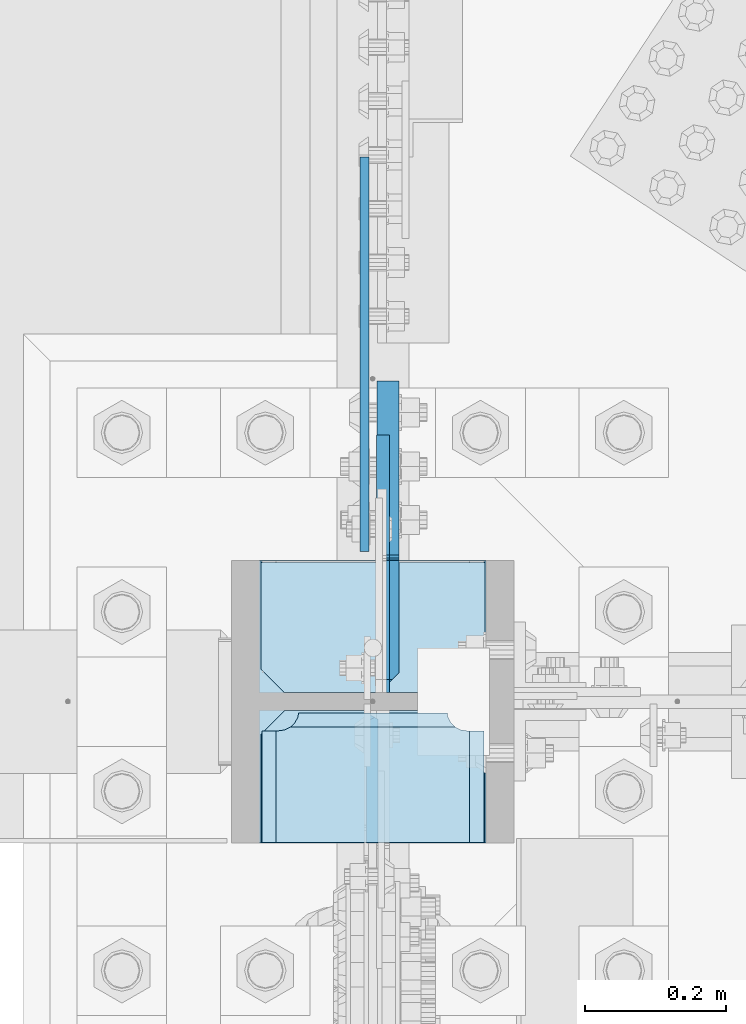
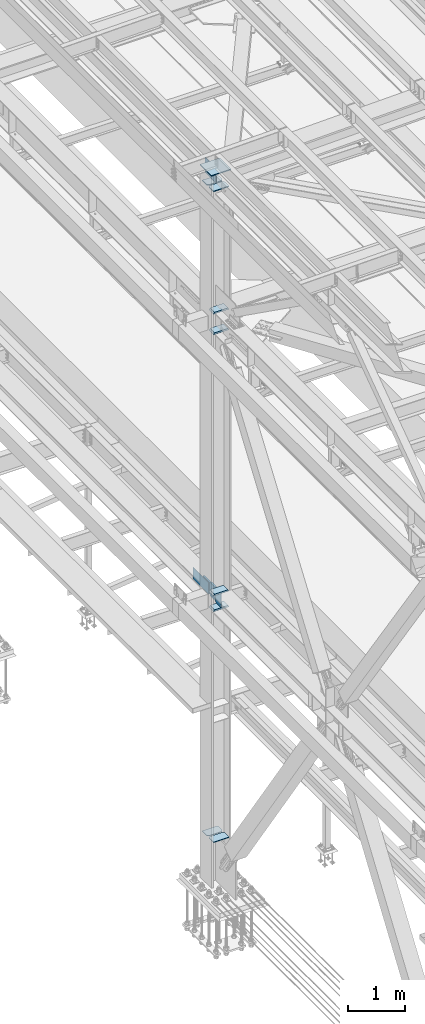
# One storey, part 3274 of 3843: 13 plates, 2 elements without a shape of their own.
"""IFC2X3 building model written with IfcOpenShell, lengths in millimetres."""

import ifcopenshell
import ifcopenshell.guid

model = None  # the IFC model being written
_history = None  # IfcOwnerHistory: only IFC2X3 demands one
_inside = {}  # id of a spatial element -> (the spatial element, [elements in it])
_under = {}  # id of a project, library or spatial element -> (it, [spatial elements below it])
_declared = {}  # id of a project -> (the project, [libraries it declares])
_typed = {}  # id of a type object -> (the type object, [elements of that type])
_made_of = {}  # id of a material, layer set ... -> (it, [elements and type objects made of it])


def new_model(schema):
    """Start an empty IFC model of exactly this schema.

    Asked for "IFC4X3", IfcOpenShell would pick the latest addendum, in which some entities
    have other attributes; the version numbers below select the first issue.
    IFC2X3 requires an IfcOwnerHistory on every rooted entity: one is made here for all.
    """
    global model, _history
    if schema == "IFC4X3":
        model = ifcopenshell.file(schema_version=(4, 3, 0, 0))
    else:
        model = ifcopenshell.file(schema=schema)
    _inside.clear()
    _under.clear()
    _declared.clear()
    _typed.clear()
    _made_of.clear()
    _history = None
    if model.schema == "IFC2X3":
        org = make("IfcOrganization", Name="unknown")
        user = make(
            "IfcPersonAndOrganization",
            ThePerson=make("IfcPerson", FamilyName="unknown"),
            TheOrganization=org,
        )
        app = make(
            "IfcApplication",
            ApplicationDeveloper=org,
            Version="unknown",
            ApplicationFullName="unknown",
            ApplicationIdentifier="unknown",
        )
        _history = make(
            "IfcOwnerHistory",
            OwningUser=user,
            OwningApplication=app,
            ChangeAction="ADDED",
            CreationDate=0,
        )
    return model


def make(cls, **values):
    """One entity of the class cls with the attributes given. An attribute that is None is left unset."""
    return model.create_entity(
        cls, **{name: value for name, value in values.items() if value is not None}
    )


def rooted(cls, **values):
    """An entity with a GlobalId (a new one), such as an element, a storey or a relation."""
    return make(cls, GlobalId=ifcopenshell.guid.new(), OwnerHistory=_history, **values)


def si_unit(unit_type, name, prefix=None):
    """IfcSIUnit, for example si_unit("LENGTHUNIT", "METRE", prefix="MILLI")."""
    return make("IfcSIUnit", UnitType=unit_type, Prefix=prefix, Name=name)


def assignment(units):
    """IfcUnitAssignment: the units of a project."""
    return None if units is None else make("IfcUnitAssignment", Units=units)


def point(xyz):
    """IfcCartesianPoint."""
    return None if xyz is None else make("IfcCartesianPoint", Coordinates=xyz)


def direction(xyz):
    """IfcDirection."""
    return None if xyz is None else make("IfcDirection", DirectionRatios=xyz)


def frame(location, z_axis=None, x_axis=None):
    """IfcAxis2Placement3D, a coordinate frame: its origin and axes. An axis left out is left unset."""
    return make(
        "IfcAxis2Placement3D",
        Location=point(location),
        Axis=direction(z_axis),
        RefDirection=direction(x_axis),
    )


def origin_with_axes():
    """The frame at (0, 0, 0) with the z axis (0, 0, 1) and the x axis (1, 0, 0) written out."""
    return frame((0.0, 0.0, 0.0), z_axis=(0.0, 0.0, 1.0), x_axis=(1.0, 0.0, 0.0))


def place(relative_to, where):
    """IfcLocalPlacement: puts the frame where relative to a parent placement (None: the world)."""
    return make(
        "IfcLocalPlacement", PlacementRelTo=relative_to, RelativePlacement=where
    )


def context(
    kind, dimensions, precision=None, world=None, true_north=None, identifier=None
):
    """IfcGeometricRepresentationContext, for example the 3D "Model" context."""
    return make(
        "IfcGeometricRepresentationContext",
        ContextIdentifier=identifier,
        ContextType=kind,
        CoordinateSpaceDimension=dimensions,
        Precision=precision,
        WorldCoordinateSystem=world,
        TrueNorth=true_north,
    )


def subcontext(parent, identifier, kind, view, scale=None):
    """IfcGeometricRepresentationSubContext, for example "Body" below "Model"."""
    return make(
        "IfcGeometricRepresentationSubContext",
        ContextIdentifier=identifier,
        ContextType=kind,
        ParentContext=parent,
        TargetScale=scale,
        TargetView=view,
    )


def project(units=None, contexts=None):
    """IfcProject with its units and contexts."""
    return rooted(
        "IfcProject",
        Name="project",
        RepresentationContexts=contexts,
        UnitsInContext=assignment(units),
    )


def spatial(cls, under=None, at=None, **own):
    """A site, building, storey or space (cls), placed at a placement, below another one or the project."""
    s = rooted(cls, ObjectPlacement=at, **own)
    if under is not None:
        _under.setdefault(under.id(), (under, []))[1].append(s)
    return s


def faces_of(points, faces, orient=None, outer=None):
    """IfcFace entities. A face is a list of loops; a loop is a list of indices into points, from 0.

    orient and outer hold one flag for each loop. By default every Orientation is true, the
    first loop of a face is its IfcFaceOuterBound and the others are IfcFaceBound.
    """
    made = []
    for i, loops in enumerate(faces):
        bounds = []
        for j, loop in enumerate(loops):
            is_outer = j == 0 if outer is None else outer[i][j]
            bounds.append(
                make(
                    "IfcFaceOuterBound" if is_outer else "IfcFaceBound",
                    Bound=make("IfcPolyLoop", Polygon=[points[k] for k in loop]),
                    Orientation=True if orient is None else orient[i][j],
                )
            )
        made.append(make("IfcFace", Bounds=bounds))
    return made


def faceted_brep(points, faces, orient=None, outer=None, voids=None):
    """IfcFacetedBrep: a solid bounded by flat faces; with voids (closed shells), ...WithVoids."""
    shared = [point(p) for p in points]
    hull = make("IfcClosedShell", CfsFaces=faces_of(shared, faces, orient, outer))
    if voids is None:
        return make("IfcFacetedBrep", Outer=hull)
    return make(
        "IfcFacetedBrepWithVoids",
        Outer=hull,
        Voids=[
            make(cls, CfsFaces=faces_of(shared, fs, o, b)) for cls, fs, o, b in voids
        ],
    )


def shape(context_of_items, identifier, shape_type, items):
    """IfcShapeRepresentation: the items that make up one representation, for example the "Body"."""
    return make(
        "IfcShapeRepresentation",
        ContextOfItems=context_of_items,
        RepresentationIdentifier=identifier,
        RepresentationType=shape_type,
        Items=items,
    )


def material(Name=None, Category=None):
    """IfcMaterial."""
    return make("IfcMaterial", Name=Name, Category=Category)


def made_of(thing, what):
    """Note that an element or type object is made of a material, layer set ...; save() writes the relation."""
    if what is not None:
        _made_of.setdefault(what.id(), (what, []))[1].append(thing)
    return thing


def type_object(cls, material=None, **own):
    """A type object (cls), such as IfcWallType, which elements share."""
    return made_of(rooted(cls, **own), material)


def element(
    cls,
    number,
    at=None,
    inside=None,
    cuts=None,
    type_object=None,
    material=None,
    context=None,
    identifier="Body",
    shape_type=None,
    held_by="IfcProductDefinitionShape",
    body=None,
    shapes=None,
    **own,
):
    """One element of the class cls, such as IfcWall. Its Tag is "e" and its number.

    at: its placement. inside: the storey or other place that contains it. cuts: it is an
    opening in that element (IfcRelVoidsElement). A single representation is given by context,
    identifier, shape_type and body (its items); several are given by shapes. held_by: the class
    of the entity that holds the representations. save() writes the other relations.
    """
    e = rooted(cls, Tag="e%d" % number, ObjectPlacement=at, **own)
    if body is not None:
        shapes = [shape(context, identifier, shape_type, body)]
    if shapes is not None:
        e.Representation = make(held_by, Representations=shapes)
    if inside is not None:
        _inside.setdefault(inside.id(), (inside, []))[1].append(e)
    if cuts is not None:
        rooted(
            "IfcRelVoidsElement", RelatingBuildingElement=cuts, RelatedOpeningElement=e
        )
    if type_object is not None:
        _typed.setdefault(type_object.id(), (type_object, []))[1].append(e)
    return made_of(e, material)


def aggregate(whole, parts):
    """IfcRelAggregates: a whole, such as a stair, and the parts it consists of."""
    return rooted("IfcRelAggregates", RelatingObject=whole, RelatedObjects=parts)


def save(model, path):
    """Write the relations noted so far, then the file.

    IfcRelAggregates (storeys below a building ...), IfcRelContainedInSpatialStructure (elements
    in a storey), IfcRelDefinesByType, IfcRelAssociatesMaterial and IfcRelDeclares: one each for
    every whole, place, type object, material and project.
    """
    for whole, parts in _under.values():
        aggregate(whole, parts)
    for where, things in _inside.values():
        rooted(
            "IfcRelContainedInSpatialStructure",
            RelatedElements=things,
            RelatingStructure=where,
        )
    for kind, things in _typed.values():
        rooted("IfcRelDefinesByType", RelatedObjects=things, RelatingType=kind)
    for what, things in _made_of.values():
        rooted("IfcRelAssociatesMaterial", RelatedObjects=things, RelatingMaterial=what)
    for by, libraries in _declared.values():
        rooted("IfcRelDeclares", RelatingContext=by, RelatedDefinitions=libraries)
    model.write(path)


model = new_model("IFC2X3")

# Units and contexts
model_context = context("Model", 3, precision=1e-05, world=origin_with_axes())
body_context = subcontext(model_context, "Body", "Model", "MODEL_VIEW")
ifc_project = project(units=[si_unit("LENGTHUNIT", "METRE", prefix="MILLI"), si_unit("AREAUNIT", "SQUARE_METRE"), si_unit("VOLUMEUNIT", "CUBIC_METRE"), si_unit("MASSUNIT", "GRAM", prefix="KILO"), si_unit("TIMEUNIT", "SECOND"), si_unit("PLANEANGLEUNIT", "RADIAN"), si_unit("SOLIDANGLEUNIT", "STERADIAN"), si_unit("THERMODYNAMICTEMPERATUREUNIT", "DEGREE_CELSIUS"), si_unit("LUMINOUSINTENSITYUNIT", "LUMEN")], contexts=[model_context])

# Site, building, storey
site_placement = place(None, origin_with_axes())
site = spatial("IfcSite", under=ifc_project, at=site_placement, CompositionType="ELEMENT")
building_placement = place(site_placement, origin_with_axes())
building = spatial("IfcBuilding", under=site, at=building_placement, Name="Undefined", CompositionType="ELEMENT")
storey_placement = place(building_placement, origin_with_axes())
storey = spatial("IfcBuildingStorey", under=building, at=storey_placement, Name="Undefined", CompositionType="ELEMENT", Elevation=0.0)

# Assembly, plates
assembly_1_placement = place(storey_placement, origin_with_axes())
assembly_1 = element("IfcElementAssembly", 1, at=assembly_1_placement, inside=storey, Name="COLUMN", AssemblyPlace="NOTDEFINED", PredefinedType="RIGID_FRAME")
ifc_material = material(Name="STEEL/A572-50")
plate_type_1 = type_object("IfcPlateType", PredefinedType="NOTDEFINED")
plate_1_placement = place(assembly_1_placement, frame((36575.2067499161, 58902.6, 36121.975), z_axis=(0.0, -0.707106781186682, 0.707106781186413), x_axis=(0.0, -0.707106781186548, -0.707106781186548)))
plate_1 = element("IfcPlate", 2, at=plate_1_placement, type_object=plate_type_1, material=ifc_material, Name="PLATE", context=body_context, shape_type="Brep", body=[
    faceted_brep([(-180.113623446363, 7.9375, 197.565634661856), (13.470384184775, 7.9375, 3.98162703046546), (13.4703841731916, 3.06102272879798, -7.27595761418343e-12), (4.49012799309094, -7.9375, 7.27595761418343e-12), (-184.095250465922, -7.9375, 188.585378458934), (-184.095250465834, 3.06102272735734, 197.565634661623), (-184.095250465747, -7.9375, 206.545890861955), (-62.8617937965901, -7.9375, 327.779349419703), (-56.3805024344765, 7.93749996326369, 321.298757561868), (22.4506403026729, -7.93750001103617, 0.0), (137.203156367104, 7.9375, 127.714399254661), (143.684450000859, -7.93749999986903, 121.233809668522), (134.703841697788, 7.9375, 130.21371389494), (134.703841697788, -7.9375, 130.21371389494), (-53.8815365549381, 7.9375, 318.799092176701), (-53.8815365549381, -7.9375, 318.799092176701)], [[[0, 1, 2, 3, 4, 5]], [[6, 7, 8, 0, 5]], [[9, 3, 2]], [[10, 11, 9, 2, 1]], [[12, 13, 11, 10]], [[14, 15, 13, 12]], [[15, 14, 8, 7]], [[4, 3, 9, 11, 13, 15, 7, 6]], [[6, 5, 4]], [[8, 14, 12, 10, 1, 0]]]),
])
plate_type_2 = type_object("IfcPlateType", PredefinedType="NOTDEFINED")
plate_2_placement = place(assembly_1_placement, frame((36415.6625, 58716.0687, 42013.1875), z_axis=(1.0, 0.0, 0.0), x_axis=(0.0, 1.0, 0.0)))
plate_2 = element("IfcPlate", 3, at=plate_2_placement, type_object=plate_type_2, material=ifc_material, Name="PLATE", context=body_context, shape_type="Brep", body=[
    faceted_brep([(169.7353359673, 6.12986484301655, 50.1051604685563), (163.413638768514, 17.0792088240414, 43.7834632697632), (163.192342336726, 17.4625000000015, 43.3491445679101), (163.192342336726, 17.4625000000015, 277.325855432093), (163.413638768514, 17.0792088240414, 276.89153673024), (169.7353359673, 6.12986484301655, 270.569839531447), (177.701139149984, -7.66711346669035, 266.511060084209), (183.356300047686, -17.4625000000015, 265.61537059048), (183.356300047686, -17.4625000000015, 55.059629409523), (177.701139149984, -7.66711346669035, 54.1639399157939), (0.0, 17.4625000000015, 297.336542336721), (0.0, -17.4625000000015, 317.500500047689), (157.956299237063, -17.4625000000015, 317.500500047689), (157.956299237063, 17.4625000000015, 297.336542336721), (157.956299237063, 17.4625000000015, 23.3384576632816), (157.956299237063, -17.4625000000015, 3.17449995231436), (0.0, -17.4625000000015, 3.17449995232164), (0.0, 17.4625000000015, 23.3384576632816), (157.956299237063, -17.4625000000015, 293.687500762942), (157.956299237063, 17.4625000000015, 293.687500762942), (159.354859321276, -17.4625000000015, 284.857339912916), (159.354859321276, 17.4625000000015, 284.857339912916), (163.413638768514, -17.4625000000015, 276.89153673024), (169.7353359673, -17.4625000000015, 270.569839531447), (177.701139149984, -17.4625000000015, 266.511060084209), (177.701139149984, -17.4625000000015, 54.1639399157939), (169.7353359673, -17.4625000000015, 50.1051604685563), (163.413638768514, -17.4625000000015, 43.7834632697632), (159.354859321276, -17.4625000000015, 35.8176600870866), (159.354859321276, 17.4625000000015, 35.8176600870866), (157.956299237063, -17.4625000000015, 26.9874992370605), (157.956299237063, 17.4625000000015, 26.9874992370605)], [[[0, 1, 2, 3, 4, 5, 6, 7, 8, 9]], [[10, 11, 12, 13]], [[14, 15, 16, 17]], [[17, 16, 11, 10]], [[18, 19, 13, 12]], [[18, 20, 21, 19]], [[21, 20, 22, 4, 3]], [[22, 23, 5, 4]], [[23, 24, 6, 5]], [[24, 7, 6]], [[25, 9, 8]], [[25, 26, 0, 9]], [[26, 27, 1, 0]], [[27, 28, 29, 2, 1]], [[28, 30, 31, 29]], [[31, 30, 15, 14]], [[29, 31, 14, 17, 10, 13, 19, 21, 3, 2]], [[15, 30, 28, 27, 26, 25, 8, 7, 24, 23, 22, 20, 18, 12, 11, 16]]]),
])
plate_3_placement = place(assembly_1_placement, frame((36415.6625, 58716.0687, 42451.3375), z_axis=(1.0, 0.0, 0.0), x_axis=(0.0, 1.0, 0.0)))
plate_3 = element("IfcPlate", 4, at=plate_3_placement, type_object=plate_type_2, material=ifc_material, Name="PLATE", context=body_context, shape_type="Brep", body=[
    faceted_brep([(169.7353359673, 6.12954035346047, 50.1051604685563), (163.413638768514, 17.0792088240414, 43.7834632697632), (163.192342336726, 17.4625000000015, 43.3491445679101), (163.192342336726, 17.4625000000015, 277.325855432093), (163.413638768514, 17.0792088240414, 276.89153673024), (169.7353359673, 6.12954035346047, 270.569839531447), (177.701139149984, -7.6678330078139, 266.511060084209), (183.356300047686, -17.4625000000015, 265.61537059048), (183.356300047686, -17.4625000000015, 55.059629409523), (177.701139149984, -7.6678330078139, 54.1639399157939), (0.0, 17.4625000000015, 297.336542336721), (0.0, -17.4625000000015, 317.500500047689), (157.956299237063, -17.4625000000015, 317.500500047689), (157.956299237063, 17.4625000000015, 297.336542336721), (157.956299237063, 17.4625000000015, 23.3384576632816), (157.956299237063, -17.4625000000015, 3.17449995231436), (0.0, -17.4625000000015, 3.17449995232164), (0.0, 17.4625000000015, 23.3384576632816), (157.956299237063, -17.4625000000015, 293.687500762942), (157.956299237063, 17.4625000000015, 293.687500762942), (159.354859321276, -17.4625000000015, 284.857339912916), (159.354859321276, 17.4625000000015, 284.857339912916), (163.413638768514, -17.4625000000015, 276.89153673024), (169.7353359673, -17.4625000000015, 270.569839531447), (177.701139149984, -17.4625000000015, 266.511060084209), (177.701139149984, -17.4625000000015, 54.1639399157939), (169.7353359673, -17.4625000000015, 50.1051604685563), (163.413638768514, -17.4625000000015, 43.7834632697632), (159.354859321276, -17.4625000000015, 35.8176600870866), (159.354859321276, 17.4625000000015, 35.8176600870866), (157.956299237063, -17.4625000000015, 26.9874992370605), (157.956299237063, 17.4625000000015, 26.9874992370605)], [[[0, 1, 2, 3, 4, 5, 6, 7, 8, 9]], [[10, 11, 12, 13]], [[14, 15, 16, 17]], [[17, 16, 11, 10]], [[18, 19, 13, 12]], [[18, 20, 21, 19]], [[21, 20, 22, 4, 3]], [[22, 23, 5, 4]], [[23, 24, 6, 5]], [[24, 7, 6]], [[25, 9, 8]], [[25, 26, 0, 9]], [[26, 27, 1, 0]], [[27, 28, 29, 2, 1]], [[28, 30, 31, 29]], [[31, 30, 15, 14]], [[29, 31, 14, 17, 10, 13, 19, 21, 3, 2]], [[15, 30, 28, 27, 26, 25, 8, 7, 24, 23, 22, 20, 18, 12, 11, 16]]]),
])
plate_4_placement = place(assembly_1_placement, frame((36415.6625, 58716.0687, 36085.4625), z_axis=(1.0, 0.0, 0.0), x_axis=(0.0, 1.0, 0.0)))
plate_4 = element("IfcPlate", 5, at=plate_4_placement, type_object=plate_type_2, material=ifc_material, Name="PLATE", context=body_context, shape_type="Brep", body=[
    faceted_brep([(169.7353359673, 6.12970259824215, 50.1051604685563), (163.413638768514, 17.0792088240414, 43.7834632697632), (163.192342336726, 17.4625000000015, 43.3491445679101), (163.192342336726, 17.4625000000015, 277.325855432093), (163.413638768514, 17.0792088240414, 276.89153673024), (169.7353359673, 6.12970259824215, 270.569839531447), (177.701139149976, -7.66747323724849, 266.511060084209), (183.356300047686, -17.4625000000015, 265.61537059048), (183.356300047686, -17.4625000000015, 55.059629409523), (177.701139149976, -7.66747323724849, 54.1639399157939), (0.0, 17.4625000000015, 297.336542336721), (0.0, -17.4625000000015, 317.500500047689), (157.956299237063, -17.4625000000015, 317.500500047689), (157.956299237063, 17.4625000000015, 297.336542336721), (157.956299237063, 17.4625000000015, 23.3384576632816), (157.956299237063, -17.4625000000015, 3.17449995231436), (0.0, -17.4625000000015, 3.17449995232164), (0.0, 17.4625000000015, 23.3384576632816), (157.956299237063, -17.4625000000015, 293.687500762942), (157.956299237063, 17.4625000000015, 293.687500762942), (159.354859321276, -17.4625000000015, 284.857339912916), (159.354859321276, 17.4625000000015, 284.857339912916), (163.413638768514, -17.4625000000015, 276.89153673024), (169.7353359673, -17.4625000000015, 270.569839531447), (177.701139149984, -17.4625000000015, 266.511060084209), (177.701139149984, -17.4625000000015, 54.1639399157939), (169.7353359673, -17.4625000000015, 50.1051604685563), (163.413638768514, -17.4625000000015, 43.7834632697632), (159.354859321276, -17.4625000000015, 35.8176600870866), (159.354859321276, 17.4625000000015, 35.8176600870866), (157.956299237063, -17.4625000000015, 26.9874992370605), (157.956299237063, 17.4625000000015, 26.9874992370605)], [[[0, 1, 2, 3, 4, 5, 6, 7, 8, 9]], [[10, 11, 12, 13]], [[14, 15, 16, 17]], [[17, 16, 11, 10]], [[18, 19, 13, 12]], [[18, 20, 21, 19]], [[21, 20, 22, 4, 3]], [[22, 23, 5, 4]], [[23, 24, 6, 5]], [[24, 7, 6]], [[25, 9, 8]], [[25, 26, 0, 9]], [[26, 27, 1, 0]], [[27, 28, 29, 2, 1]], [[28, 30, 31, 29]], [[31, 30, 15, 14]], [[29, 31, 14, 17, 10, 13, 19, 21, 3, 2]], [[15, 30, 28, 27, 26, 25, 8, 7, 24, 23, 22, 20, 18, 12, 11, 16]]]),
])
plate_5_placement = place(assembly_1_placement, frame((36415.6625, 58716.0687, 36418.8375), z_axis=(1.0, 0.0, 0.0), x_axis=(0.0, 1.0, 0.0)))
plate_5 = element("IfcPlate", 6, at=plate_5_placement, type_object=plate_type_2, material=ifc_material, Name="PLATE", context=body_context, shape_type="Brep", body=[
    faceted_brep([(169.7353359673, 6.12970259824215, 50.1051604685563), (163.413638768514, 17.0792088240414, 43.7834632697632), (163.192342336726, 17.4625000000015, 43.3491445679101), (163.192342336726, 17.4625000000015, 277.325855432093), (163.413638768514, 17.0792088240414, 276.89153673024), (169.7353359673, 6.12970259824215, 270.569839531447), (177.701139149976, -7.66747323724849, 266.511060084209), (183.356300047686, -17.4625000000015, 265.61537059048), (183.356300047686, -17.4625000000015, 55.059629409523), (177.701139149976, -7.66747323724849, 54.1639399157939), (0.0, 17.4625000000015, 297.336542336721), (0.0, -17.4625000000015, 317.500500047689), (157.956299237063, -17.4625000000015, 317.500500047689), (157.956299237063, 17.4625000000015, 297.336542336721), (157.956299237063, 17.4625000000015, 23.3384576632816), (157.956299237063, -17.4625000000015, 3.17449995231436), (0.0, -17.4625000000015, 3.17449995232164), (0.0, 17.4625000000015, 23.3384576632816), (157.956299237063, -17.4625000000015, 293.687500762942), (157.956299237063, 17.4625000000015, 293.687500762942), (159.354859321276, -17.4625000000015, 284.857339912916), (159.354859321276, 17.4625000000015, 284.857339912916), (163.413638768514, -17.4625000000015, 276.89153673024), (169.7353359673, -17.4625000000015, 270.569839531447), (177.701139149984, -17.4625000000015, 266.511060084209), (177.701139149984, -17.4625000000015, 54.1639399157939), (169.7353359673, -17.4625000000015, 50.1051604685563), (163.413638768514, -17.4625000000015, 43.7834632697632), (159.354859321276, -17.4625000000015, 35.8176600870866), (159.354859321276, 17.4625000000015, 35.8176600870866), (157.956299237063, -17.4625000000015, 26.9874992370605), (157.956299237063, 17.4625000000015, 26.9874992370605)], [[[0, 1, 2, 3, 4, 5, 6, 7, 8, 9]], [[10, 11, 12, 13]], [[14, 15, 16, 17]], [[17, 16, 11, 10]], [[18, 19, 13, 12]], [[18, 20, 21, 19]], [[21, 20, 22, 4, 3]], [[22, 23, 5, 4]], [[23, 24, 6, 5]], [[24, 7, 6]], [[25, 9, 8]], [[25, 26, 0, 9]], [[26, 27, 1, 0]], [[27, 28, 29, 2, 1]], [[28, 30, 31, 29]], [[31, 30, 15, 14]], [[29, 31, 14, 17, 10, 13, 19, 21, 3, 2]], [[15, 30, 28, 27, 26, 25, 8, 7, 24, 23, 22, 20, 18, 12, 11, 16]]]),
])
plate_type_3 = type_object("IfcPlateType", PredefinedType="NOTDEFINED")
plate_6_placement = place(assembly_1_placement, frame((36734.75, 59112.15, 45059.5999999995), z_axis=(-1.0, 0.0, 0.0), x_axis=(0.0, -1.0, 0.0)))
plate_6 = element("IfcPlate", 7, at=plate_6_placement, type_object=plate_type_3, material=ifc_material, Name="PLATE", context=body_context, shape_type="Brep", body=[
    faceted_brep([(0.0, -9.52500000000146, 0.0), (0.0, -9.52500000000146, 317.5), (0.0, 9.52500000000146, 317.5), (0.0, 9.52500000000146, 0.0), (150.81249847413, -9.52500000000146, 317.5), (150.81249847413, 9.52500000000146, 317.5), (184.150000000009, -9.52500000000146, 284.162498474121), (184.150000000009, 9.52500000000146, 284.162498474121), (184.150000000009, -9.52500000000146, 33.3375015258789), (184.150000000009, 9.52500000000146, 33.3375015258789), (150.81249847413, -9.52500000000146, 0.0), (150.81249847413, 9.52500000000146, 0.0)], [[[0, 1, 2, 3]], [[1, 4, 5, 2]], [[4, 6, 7, 5]], [[6, 8, 9, 7]], [[8, 10, 11, 9]], [[10, 0, 3, 11]], [[5, 7, 9, 11, 3, 2]], [[10, 8, 6, 4, 1, 0]]]),
])
plate_7_placement = place(assembly_1_placement, frame((36417.25, 58718.45, 45059.599999988), z_axis=(1.0, 0.0, 0.0), x_axis=(0.0, 1.0, 0.0)))
plate_7 = element("IfcPlate", 8, at=plate_7_placement, type_object=plate_type_3, material=ifc_material, Name="PLATE", context=body_context, shape_type="Brep", body=[
    faceted_brep([(0.0, -9.52500000000146, 0.0), (0.0, -9.52500000000146, 317.5), (0.0, 9.52500000000146, 317.5), (0.0, 9.52500000000146, 0.0), (150.81249847413, -9.52500000000146, 317.5), (150.81249847413, 9.52500000000146, 317.5), (184.150000000009, -9.52500000000146, 284.162498474121), (184.150000000009, 9.52500000000146, 284.162498474121), (184.150000000009, -9.52500000000146, 33.3375015258789), (184.150000000009, 9.52500000000146, 33.3375015258789), (150.81249847413, -9.52500000000146, 0.0), (150.81249847413, 9.52500000000146, 0.0)], [[[0, 1, 2, 3]], [[1, 4, 5, 2]], [[4, 6, 7, 5]], [[6, 8, 9, 7]], [[8, 10, 11, 9]], [[10, 0, 3, 11]], [[5, 7, 9, 11, 3, 2]], [[10, 8, 6, 4, 1, 0]]]),
])
plate_type_4 = type_object("IfcPlateType", PredefinedType="NOTDEFINED")
plate_8_placement = place(assembly_1_placement, frame((36734.75, 58928.0, 31130.1545659526), z_axis=(0.0, 1.0, 0.0), x_axis=(-1.0, 0.0, 0.0)))
plate_8 = element("IfcPlate", 9, at=plate_8_placement, type_object=plate_type_4, material=ifc_material, Name="CB_COL", context=body_context, shape_type="Brep", body=[
    faceted_brep([(0.0, -6.34999999999854, 33.3375015258789), (0.0, -6.34999999999854, 187.324999999997), (0.0, 6.34999999999854, 187.324999999997), (0.0, 6.34999999999854, 33.3375015258789), (317.5, -6.34999999999854, 187.324999999997), (317.5, 6.34999999999854, 187.324999999997), (317.499999999985, -6.34999999999854, 33.3375015258789), (317.499999999985, 6.34999999999854, 33.3375015258789), (284.162498474107, -6.34999999999854, 0.0), (284.162498474107, 6.34999999999854, 0.0), (33.3375015258789, -6.34999999999854, 0.0), (33.3375015258789, 6.34999999999854, 0.0)], [[[0, 1, 2, 3]], [[1, 4, 5, 2]], [[4, 6, 7, 5]], [[6, 8, 9, 7]], [[8, 10, 11, 9]], [[10, 0, 3, 11]], [[5, 7, 9, 11, 3, 2]], [[10, 8, 6, 4, 1, 0]]]),
])
plate_9_placement = place(assembly_1_placement, frame((36734.75, 58902.6, 31130.1545659526), z_axis=(0.0, -1.0, 0.0), x_axis=(-1.0, 0.0, 0.0)))
plate_9 = element("IfcPlate", 10, at=plate_9_placement, type_object=plate_type_4, material=ifc_material, Name="CB_COL", context=body_context, shape_type="Brep", body=[
    faceted_brep([(0.0, -6.34999999999854, 33.3375015258789), (0.0, -6.34999999999854, 187.324999999997), (0.0, 6.34999999999854, 187.324999999997), (0.0, 6.34999999999854, 33.3375015258789), (317.5, -6.34999999999854, 187.324999999997), (317.5, 6.34999999999854, 187.324999999997), (317.499999999985, -6.34999999999854, 33.3375015258789), (317.499999999985, 6.34999999999854, 33.3375015258789), (284.162498474107, -6.34999999999854, 0.0), (284.162498474107, 6.34999999999854, 0.0), (33.3375015258789, -6.34999999999854, 0.0), (33.3375015258789, 6.34999999999854, 0.0)], [[[0, 1, 2, 3]], [[1, 4, 5, 2]], [[4, 6, 7, 5]], [[6, 8, 9, 7]], [[8, 10, 11, 9]], [[10, 0, 3, 11]], [[5, 7, 9, 11, 3, 2]], [[10, 8, 6, 4, 1, 0]]]),
])
plate_type_5 = type_object("IfcPlateType", PredefinedType="NOTDEFINED")
plate_10_placement = place(assembly_1_placement, frame((36590.2875004278, 58928.0, 45088.1750027919), z_axis=(0.0, 0.707106781186548, 0.707106781186548), x_axis=(5.70000238222118e-08, 0.707106781186546, -0.707106781186546)))
plate_10 = element("IfcPlate", 11, at=plate_10_placement, type_object=plate_type_5, material=ifc_material, Name="PLATE", context=body_context, shape_type="Brep", body=[
    faceted_brep([(0.0, -9.52500000000146, 0.0), (-206.545892322774, -9.52500000000146, 206.545889244429), (-206.545892322774, 9.52500000000146, 206.545889244429), (0.0, 9.52500000000146, 0.0), (-206.545892322807, -9.52500000000146, 233.486657406793), (-206.545892322807, 9.52500000000146, 233.486657406793), (-87.5574981562204, -9.52500000000146, 352.475049513436), (-87.5574981562204, 9.52500000000146, 352.475049513436), (-83.4373216675631, -9.52500000000146, 349.722035643659), (-83.4373216675631, 9.52500000000146, 349.722035643659), (-78.5772421423244, -9.52500000000146, 348.755305757295), (-78.5772421423244, 9.52500000000146, 348.755305757295), (-73.7171626314957, -9.52500000000146, 349.722035716099), (-73.7171626314957, 9.52500000000146, 349.722035716099), (-69.5969861838676, -9.52500000000146, 352.47504964727), (-69.5969861838676, 9.52500000000146, 352.47504964727), (47.1463462352222, -9.52500000000146, 469.218383806307), (47.1463462352222, 9.52500000000146, 469.218383806307), (271.652750933881, -9.52500000000146, 244.711982453664), (271.652750933881, 9.52500000000146, 244.711982453664), (26.9407683632344, -9.52499999999964, 2.03726813197136e-10), (26.9407683632344, 9.52499999999964, 2.03726813197136e-10)], [[[0, 1, 2, 3]], [[1, 4, 5, 2]], [[4, 6, 7, 5]], [[6, 8, 9, 7]], [[8, 10, 11, 9]], [[10, 12, 13, 11]], [[12, 14, 15, 13]], [[14, 16, 17, 15]], [[16, 18, 19, 17]], [[18, 20, 21, 19]], [[20, 0, 3, 21]], [[5, 7, 9, 11, 13, 15, 17, 19, 21, 3, 2]], [[20, 18, 16, 14, 12, 10, 8, 6, 4, 1, 0]]]),
])
plate_type_6 = type_object("IfcPlateType", PredefinedType="NOTDEFINED")
plate_11_placement = place(assembly_1_placement, frame((36776.025, 58715.2745, 45410.1797065825), z_axis=(-1.0, 0.0, 0.0), x_axis=(0.0, 1.0, 0.0)))
plate_11 = element("IfcPlate", 12, at=plate_11_placement, type_object=plate_type_6, material=ifc_material, Name="PLATE", context=body_context, shape_type="Brep", body=[
    faceted_brep([(0.0, -9.52500000000146, 0.0), (0.000500003050547093, -9.52500000000146, 400.049999996474), (0.000500003050547093, 9.52500000000146, 400.049999996474), (0.0, 9.52500000000146, 0.0), (400.050500003053, -9.52500000000146, 400.049999995354), (400.050500003053, 9.52500000000146, 400.049999995354), (400.049999999988, -9.52500000000146, -1.1423253454268e-09), (400.049999999988, 9.52500000000146, -1.1423253454268e-09)], [[[0, 1, 2, 3]], [[1, 4, 5, 2]], [[4, 6, 7, 5]], [[6, 0, 3, 7]], [[5, 7, 3, 2]], [[6, 4, 1, 0]]]),
])

# Assembly, plate
assembly_2_placement = place(storey_placement, origin_with_axes())
assembly_2 = element("IfcElementAssembly", 13, at=assembly_2_placement, inside=storey, Name="BEAM", AssemblyPlace="NOTDEFINED", PredefinedType="RIGID_FRAME")
plate_type_7 = type_object("IfcPlateType", PredefinedType="NOTDEFINED")
plate_12_placement = place(assembly_2_placement, frame((36564.09375, 59686.825012207, 36385.5000000001), z_axis=(0.0, -1.0, 0.0), x_axis=(0.0, 0.0, -1.0)))
plate_12 = element("IfcPlate", 14, at=plate_12_placement, type_object=plate_type_7, material=ifc_material, Name="PLATE", context=body_context, shape_type="Brep", body=[
    faceted_brep([(0.0, -6.3499999046162, 0.0), (-1.27693056128919e-09, -6.34999999999854, 558.800000006726), (0.0, 6.35000000000036, 558.799999999988), (7.27595761418343e-12, 6.3499999046162, 0.0), (241.300003051758, -6.34999999999854, 558.800012207037), (241.300003051758, 6.34999999999854, 558.800012207037), (241.300003051758, -6.34999999999854, 0.0), (241.300003051758, 6.34999999999854, 0.0)], [[[0, 1, 2, 3]], [[1, 4, 5, 2]], [[4, 6, 7, 5]], [[6, 0, 3, 7]], [[5, 7, 3, 2]], [[6, 4, 1, 0]]]),
])
aggregate(assembly_2, [plate_12])

# Plate
plate_type_8 = type_object("IfcPlateType", PredefinedType="NOTDEFINED")
plate_13_placement = place(assembly_1_placement, frame((36597.43125, 58928.0, 36401.375), z_axis=(0.0, 1.0, 0.0), x_axis=(0.0, 0.0, -1.0)))
plate_13 = element("IfcPlate", 15, at=plate_13_placement, type_object=plate_type_8, material=ifc_material, Name="PLATE", context=body_context, shape_type="Brep", body=[
    faceted_brep([(298.449999999997, -15.875, 28.5749999999971), (0.0, -15.875, 28.5750007629395), (0.0, -6.34999999999854, 19.0499992370605), (19.0500015258731, 12.6999999999971, 0.0), (279.400000762937, 12.6999999999971, 0.0), (298.449999999997, -6.34999923706346, 19.0499992370605), (0.0, -15.875, 187.325000000004), (0.0, 15.875, 187.325000000004), (0.0, 15.875, 19.0499992370605), (3.17500019070576, -15.875, 187.325000000004), (3.17500019070576, 15.875, 187.325000000004), (8.03507970875216, -15.875, 188.291729922596), (8.03507970875216, 15.875, 188.291729922596), (12.1552561769058, -15.875, 191.044743823069), (12.1552561769058, 15.875, 191.044743823069), (14.908270077387, -15.875, 195.164920291223), (14.908270077387, 15.875, 195.164920291223), (15.8749999999709, -15.875, 200.02499980927), (15.8749999999709, 15.875, 200.02499980927), (15.875, -15.875, 441.325012207031), (15.875, 15.875, 441.325012207031), (257.175003051758, -15.875, 441.325012207031), (257.175003051758, 15.875, 441.325012207031), (257.175003051729, -15.875, 200.02499980927), (257.175003051729, 15.875, 200.02499980927), (258.14173297432, -15.875, 195.164920291223), (258.14173297432, 15.875, 195.164920291223), (260.894746874794, -15.875, 191.044743823069), (260.894746874794, 15.875, 191.044743823069), (265.014923342947, -15.875, 188.291729922596), (265.014923342947, 15.875, 188.291729922596), (269.875002860994, -15.875, 187.325000000004), (269.875002860994, 15.875, 187.325000000004), (298.449999999997, -15.875, 187.325000000004), (298.449999999997, 15.875, 187.325000000004), (298.449999999997, 15.875, 19.0499992370605), (279.400000762937, 15.875, 0.0), (19.0500015258804, 15.875, 0.0)], [[[0, 1, 2, 3, 4, 5]], [[6, 7, 8, 2, 1]], [[6, 9, 10, 7]], [[9, 11, 12, 10]], [[11, 13, 14, 12]], [[13, 15, 16, 14]], [[15, 17, 18, 16]], [[17, 19, 20, 18]], [[19, 21, 22, 20]], [[21, 23, 24, 22]], [[23, 25, 26, 24]], [[25, 27, 28, 26]], [[27, 29, 30, 28]], [[29, 31, 32, 30]], [[31, 33, 34, 32]], [[35, 34, 33, 0, 5]], [[36, 35, 5, 4]], [[37, 36, 4, 3]], [[8, 37, 3, 2]], [[10, 12, 14, 16, 18, 20, 22, 24, 26, 28, 30, 32, 34, 35, 36, 37, 8, 7]], [[33, 31, 29, 27, 25, 23, 21, 19, 17, 15, 13, 11, 9, 6, 1, 0]]]),
])

aggregate(assembly_1, [plate_8, plate_9, plate_11, plate_2, plate_3, plate_6, plate_10, plate_7, plate_4, plate_5, plate_1, plate_13])

save(model, "model.ifc")
